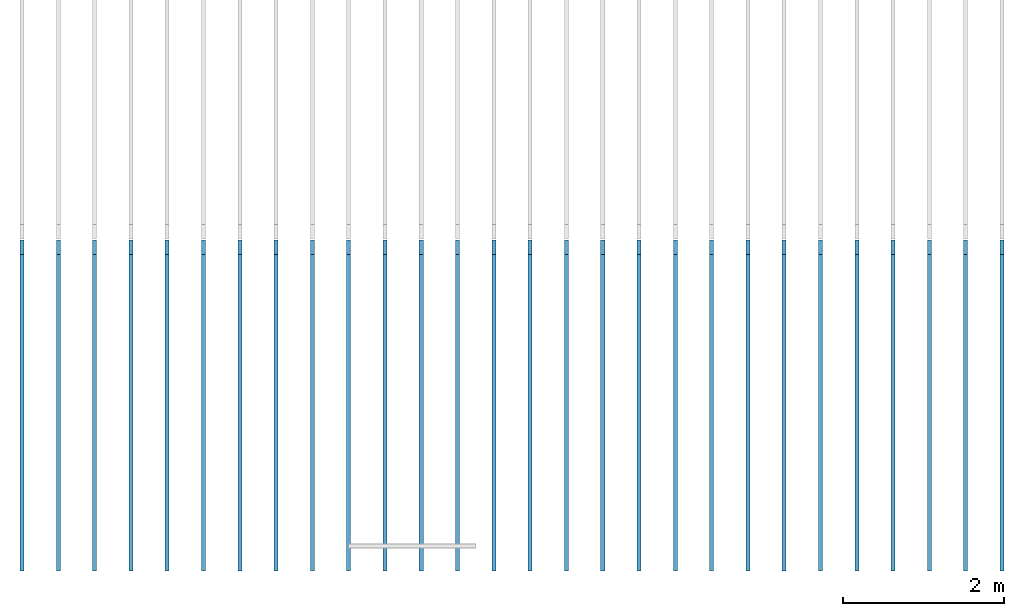
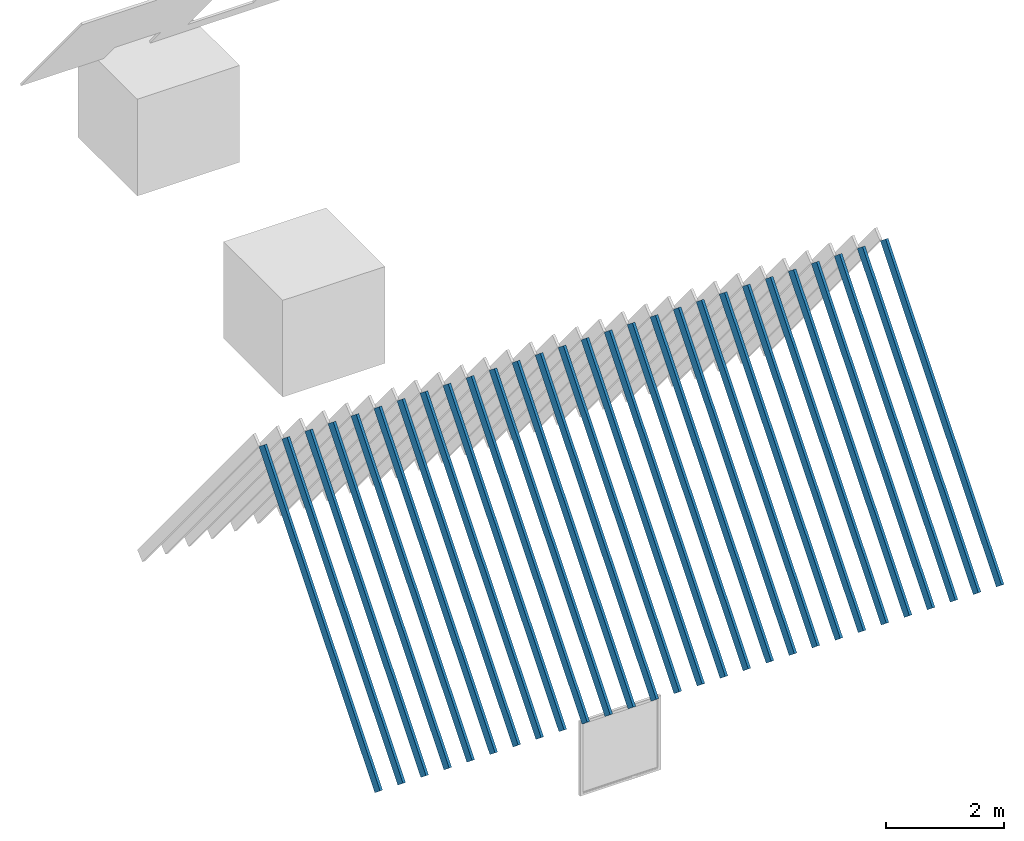
# Not in any storey, part 1 of 4: 1 member.
"""IFC4 model written with IfcOpenShell, lengths in metres."""

from ifc_helpers import new_model, entity, si_unit, converted_unit, frame, frame_2d, origin_with_axes, place, context, project, polygons, shape, element, save


model = new_model("IFC4")

# Units and contexts
model_context = context("Model", 3, precision=1e-05, world=origin_with_axes())
plan_context = context("Plan", 2, precision=1e-05, world=frame_2d((0.0, 0.0, 0.0), x_axis=(1.0, 0.0, 0.0)))
ifc_project = project(units=[si_unit("AREAUNIT", "SQUARE_METRE"), si_unit("VOLUMEUNIT", "CUBIC_METRE"), si_unit("LENGTHUNIT", "METRE"), converted_unit("PLANEANGLEUNIT", "degree", entity("IfcReal", 0.0174532925199433), si_unit("PLANEANGLEUNIT", "RADIAN"), dimensions=[0, 0, 0, 0, 0, 0, 0])], contexts=[model_context, plan_context])

# Member
member_placement = place(None, frame((-7.88622856140137, -14.2160263061523, 4.8522891998291), z_axis=(1.0, 5.00048429330491e-07, -1.79189484583731e-07), x_axis=(-1.79189484583731e-07, 0.635131001472473, 0.772404432296753)))
element("IfcMember", 1, at=member_placement, Name="Roof_Joists", PredefinedType="BRACE", shapes=[
    shape(model_context, None, "Tessellation", [polygons([(-3.09032249450684, -0.114181444048882, -0.025000000372529), (3.09032249450684, -0.114181444048882, -0.025000000372529), (-3.09032249450684, 0.114181444048882, -0.025000000372529), (3.09032249450684, 0.114181444048882, -0.025000000372529), (-3.09032249450684, 0.114181444048882, 0.025000000372529), (3.09032249450684, 0.114181444048882, 0.025000000372529), (-3.09032249450684, -0.114181444048882, 0.025000000372529), (3.09032249450684, -0.114181444048882, 0.025000000372529), (-3.09032249450684, -0.114181444048882, 0.424999982118607), (3.09032249450684, -0.114181444048882, 0.424999982118607), (-3.09032249450684, 0.114181444048882, 0.424999982118607), (3.09032249450684, 0.114181444048882, 0.424999982118607), (-3.09032249450684, 0.114181444048882, 0.474999994039536), (3.09032249450684, 0.114181444048882, 0.474999994039536), (-3.09032249450684, -0.114181444048882, 0.474999994039536), (3.09032249450684, -0.114181444048882, 0.474999994039536), (-3.09032249450684, -0.114181444048882, 0.875), (3.09032249450684, -0.114181444048882, 0.875), (-3.09032249450684, 0.114181444048882, 0.875), (3.09032249450684, 0.114181444048882, 0.875), (-3.09032249450684, 0.114181444048882, 0.924999952316284), (3.09032249450684, 0.114181444048882, 0.924999952316284), (-3.09032249450684, -0.114181444048882, 0.924999952316284), (3.09032249450684, -0.114181444048882, 0.924999952316284), (-3.09032249450684, -0.114181444048882, 1.32499992847443), (3.09032249450684, -0.114181444048882, 1.32499992847443), (-3.09032249450684, 0.114181444048882, 1.32499992847443), (3.09032249450684, 0.114181444048882, 1.32499992847443), (-3.09032249450684, 0.114181444048882, 1.37499988079071), (3.09032249450684, 0.114181444048882, 1.37499988079071), (-3.09032249450684, -0.114181444048882, 1.37499988079071), (3.09032249450684, -0.114181444048882, 1.37499988079071), (-3.09032249450684, -0.114181444048882, 1.77499997615814), (3.09032249450684, -0.114181444048882, 1.77499997615814), (-3.09032249450684, 0.114181444048882, 1.77499997615814), (3.09032249450684, 0.114181444048882, 1.77499997615814), (-3.09032249450684, 0.114181444048882, 1.82499992847443), (3.09032249450684, 0.114181444048882, 1.82499992847443), (-3.09032249450684, -0.114181444048882, 1.82499992847443), (3.09032249450684, -0.114181444048882, 1.82499992847443), (-3.09032249450684, -0.114181444048882, 2.22499990463257), (3.09032249450684, -0.114181444048882, 2.22499990463257), (-3.09032249450684, 0.114181444048882, 2.22499990463257), (3.09032249450684, 0.114181444048882, 2.22499990463257), (-3.09032249450684, 0.114181444048882, 2.27500009536743), (3.09032249450684, 0.114181444048882, 2.27500009536743), (-3.09032249450684, -0.114181444048882, 2.27500009536743), (3.09032249450684, -0.114181444048882, 2.27500009536743), (-3.09032249450684, -0.114181444048882, 2.67499995231628), (3.09032249450684, -0.114181444048882, 2.67499995231628), (-3.09032249450684, 0.114181444048882, 2.67499995231628), (3.09032249450684, 0.114181444048882, 2.67499995231628), (-3.09032249450684, 0.114181444048882, 2.72500014305115), (3.09032249450684, 0.114181444048882, 2.72500014305115), (-3.09032249450684, -0.114181444048882, 2.72500014305115), (3.09032249450684, -0.114181444048882, 2.72500014305115), (-3.09032249450684, -0.114181444048882, 3.125), (3.09032249450684, -0.114181444048882, 3.125), (-3.09032249450684, 0.114181444048882, 3.125), (3.09032249450684, 0.114181444048882, 3.125), (-3.09032249450684, 0.114181444048882, 3.17500019073486), (3.09032249450684, 0.114181444048882, 3.17500019073486), (-3.09032249450684, -0.114181444048882, 3.17500019073486), (3.09032249450684, -0.114181444048882, 3.17500019073486), (-3.09032249450684, -0.114181444048882, 3.57500004768372), (3.09032249450684, -0.114181444048882, 3.57500004768372), (-3.09032249450684, 0.114181444048882, 3.57500004768372), (3.09032249450684, 0.114181444048882, 3.57500004768372), (-3.09032249450684, 0.114181444048882, 3.62500023841858), (3.09032249450684, 0.114181444048882, 3.62500023841858), (-3.09032249450684, -0.114181444048882, 3.62500023841858), (3.09032249450684, -0.114181444048882, 3.62500023841858), (-3.09032249450684, -0.114181444048882, 4.02500009536743), (3.09032249450684, -0.114181444048882, 4.02500009536743), (-3.09032249450684, 0.114181444048882, 4.02500009536743), (3.09032249450684, 0.114181444048882, 4.02500009536743), (-3.09032249450684, 0.114181444048882, 4.07500028610229), (3.09032249450684, 0.114181444048882, 4.07500028610229), (-3.09032249450684, -0.114181444048882, 4.07500028610229), (3.09032249450684, -0.114181444048882, 4.07500028610229), (-3.09032249450684, -0.114181444048882, 4.47499990463257), (3.09032249450684, -0.114181444048882, 4.47499990463257), (-3.09032249450684, 0.114181444048882, 4.47499990463257), (3.09032249450684, 0.114181444048882, 4.47499990463257), (-3.09032249450684, 0.114181444048882, 4.52500009536743), (3.09032249450684, 0.114181444048882, 4.52500009536743), (-3.09032249450684, -0.114181444048882, 4.52500009536743), (3.09032249450684, -0.114181444048882, 4.52500009536743), (-3.09032249450684, -0.114181444048882, 4.92499971389771), (3.09032249450684, -0.114181444048882, 4.92499971389771), (-3.09032249450684, 0.114181444048882, 4.92499971389771), (3.09032249450684, 0.114181444048882, 4.92499971389771), (-3.09032249450684, 0.114181444048882, 4.97499990463257), (3.09032249450684, 0.114181444048882, 4.97499990463257), (-3.09032249450684, -0.114181444048882, 4.97499990463257), (3.09032249450684, -0.114181444048882, 4.97499990463257), (-3.09032249450684, -0.114181444048882, 5.37499952316284), (3.09032249450684, -0.114181444048882, 5.37499952316284), (-3.09032249450684, 0.114181444048882, 5.37499952316284), (3.09032249450684, 0.114181444048882, 5.37499952316284), (-3.09032249450684, 0.114181444048882, 5.42499971389771), (3.09032249450684, 0.114181444048882, 5.42499971389771), (-3.09032249450684, -0.114181444048882, 5.42499971389771), (3.09032249450684, -0.114181444048882, 5.42499971389771), (-3.09032249450684, -0.114181444048882, 5.82499933242798), (3.09032249450684, -0.114181444048882, 5.82499933242798), (-3.09032249450684, 0.114181444048882, 5.82499933242798), (3.09032249450684, 0.114181444048882, 5.82499933242798), (-3.09032249450684, 0.114181444048882, 5.87499952316284), (3.09032249450684, 0.114181444048882, 5.87499952316284), (-3.09032249450684, -0.114181444048882, 5.87499952316284), (3.09032249450684, -0.114181444048882, 5.87499952316284), (-3.09032249450684, -0.114181444048882, 6.27499914169312), (3.09032249450684, -0.114181444048882, 6.27499914169312), (-3.09032249450684, 0.114181444048882, 6.27499914169312), (3.09032249450684, 0.114181444048882, 6.27499914169312), (-3.09032249450684, 0.114181444048882, 6.32499933242798), (3.09032249450684, 0.114181444048882, 6.32499933242798), (-3.09032249450684, -0.114181444048882, 6.32499933242798), (3.09032249450684, -0.114181444048882, 6.32499933242798), (-3.09032249450684, -0.114181444048882, 6.72499895095825), (3.09032249450684, -0.114181444048882, 6.72499895095825), (-3.09032249450684, 0.114181444048882, 6.72499895095825), (3.09032249450684, 0.114181444048882, 6.72499895095825), (-3.09032249450684, 0.114181444048882, 6.77499914169312), (3.09032249450684, 0.114181444048882, 6.77499914169312), (-3.09032249450684, -0.114181444048882, 6.77499914169312), (3.09032249450684, -0.114181444048882, 6.77499914169312), (-3.09032249450684, -0.114181444048882, 7.17499876022339), (3.09032249450684, -0.114181444048882, 7.17499876022339), (-3.09032249450684, 0.114181444048882, 7.17499876022339), (3.09032249450684, 0.114181444048882, 7.17499876022339), (-3.09032249450684, 0.114181444048882, 7.22499895095825), (3.09032249450684, 0.114181444048882, 7.22499895095825), (-3.09032249450684, -0.114181444048882, 7.22499895095825), (3.09032249450684, -0.114181444048882, 7.22499895095825), (-3.09032249450684, -0.114181444048882, 7.62499856948853), (3.09032249450684, -0.114181444048882, 7.62499856948853), (-3.09032249450684, 0.114181444048882, 7.62499856948853), (3.09032249450684, 0.114181444048882, 7.62499856948853), (-3.09032249450684, 0.114181444048882, 7.67499876022339), (3.09032249450684, 0.114181444048882, 7.67499876022339), (-3.09032249450684, -0.114181444048882, 7.67499876022339), (3.09032249450684, -0.114181444048882, 7.67499876022339), (-3.09032249450684, -0.114181444048882, 8.07499885559082), (3.09032249450684, -0.114181444048882, 8.07499885559082), (-3.09032249450684, 0.114181444048882, 8.07499885559082), (3.09032249450684, 0.114181444048882, 8.07499885559082), (-3.09032249450684, 0.114181444048882, 8.12499809265137), (3.09032249450684, 0.114181444048882, 8.12499809265137), (-3.09032249450684, -0.114181444048882, 8.12499809265137), (3.09032249450684, -0.114181444048882, 8.12499809265137), (-3.09032249450684, -0.114181444048882, 8.52499866485596), (3.09032249450684, -0.114181444048882, 8.52499866485596), (-3.09032249450684, 0.114181444048882, 8.52499866485596), (3.09032249450684, 0.114181444048882, 8.52499866485596), (-3.09032249450684, 0.114181444048882, 8.5749979019165), (3.09032249450684, 0.114181444048882, 8.5749979019165), (-3.09032249450684, -0.114181444048882, 8.5749979019165), (3.09032249450684, -0.114181444048882, 8.5749979019165), (-3.09032249450684, -0.114181444048882, 8.97499847412109), (3.09032249450684, -0.114181444048882, 8.97499847412109), (-3.09032249450684, 0.114181444048882, 8.97499847412109), (3.09032249450684, 0.114181444048882, 8.97499847412109), (-3.09032249450684, 0.114181444048882, 9.02499771118164), (3.09032249450684, 0.114181444048882, 9.02499771118164), (-3.09032249450684, -0.114181444048882, 9.02499771118164), (3.09032249450684, -0.114181444048882, 9.02499771118164), (-3.09032249450684, -0.114181444048882, 9.42499828338623), (3.09032249450684, -0.114181444048882, 9.42499828338623), (-3.09032249450684, 0.114181444048882, 9.42499828338623), (3.09032249450684, 0.114181444048882, 9.42499828338623), (-3.09032249450684, 0.114181444048882, 9.47499752044678), (3.09032249450684, 0.114181444048882, 9.47499752044678), (-3.09032249450684, -0.114181444048882, 9.47499752044678), (3.09032249450684, -0.114181444048882, 9.47499752044678), (-3.09032249450684, -0.114181444048882, 9.87499809265137), (3.09032249450684, -0.114181444048882, 9.87499809265137), (-3.09032249450684, 0.114181444048882, 9.87499809265137), (3.09032249450684, 0.114181444048882, 9.87499809265137), (-3.09032249450684, 0.114181444048882, 9.92499732971191), (3.09032249450684, 0.114181444048882, 9.92499732971191), (-3.09032249450684, -0.114181444048882, 9.92499732971191), (3.09032249450684, -0.114181444048882, 9.92499732971191), (-3.09032249450684, -0.114181444048882, 10.3249979019165), (3.09032249450684, -0.114181444048882, 10.3249979019165), (-3.09032249450684, 0.114181444048882, 10.3249979019165), (3.09032249450684, 0.114181444048882, 10.3249979019165), (-3.09032249450684, 0.114181444048882, 10.3749971389771), (3.09032249450684, 0.114181444048882, 10.3749971389771), (-3.09032249450684, -0.114181444048882, 10.3749971389771), (3.09032249450684, -0.114181444048882, 10.3749971389771), (-3.09032249450684, -0.114181444048882, 10.7749977111816), (3.09032249450684, -0.114181444048882, 10.7749977111816), (-3.09032249450684, 0.114181444048882, 10.7749977111816), (3.09032249450684, 0.114181444048882, 10.7749977111816), (-3.09032249450684, 0.114181444048882, 10.8249969482422), (3.09032249450684, 0.114181444048882, 10.8249969482422), (-3.09032249450684, -0.114181444048882, 10.8249969482422), (3.09032249450684, -0.114181444048882, 10.8249969482422), (-3.09032249450684, -0.114181444048882, 11.2249975204468), (3.09032249450684, -0.114181444048882, 11.2249975204468), (-3.09032249450684, 0.114181444048882, 11.2249975204468), (3.09032249450684, 0.114181444048882, 11.2249975204468), (-3.09032249450684, 0.114181444048882, 11.2749967575073), (3.09032249450684, 0.114181444048882, 11.2749967575073), (-3.09032249450684, -0.114181444048882, 11.2749967575073), (3.09032249450684, -0.114181444048882, 11.2749967575073), (-3.09032249450684, -0.114181444048882, 11.6749973297119), (3.09032249450684, -0.114181444048882, 11.6749973297119), (-3.09032249450684, 0.114181444048882, 11.6749973297119), (3.09032249450684, 0.114181444048882, 11.6749973297119), (-3.09032249450684, 0.114181444048882, 11.7249965667725), (3.09032249450684, 0.114181444048882, 11.7249965667725), (-3.09032249450684, -0.114181444048882, 11.7249965667725), (3.09032249450684, -0.114181444048882, 11.7249965667725), (-3.09032249450684, -0.114181444048882, 12.1249971389771), (3.09032249450684, -0.114181444048882, 12.1249971389771), (-3.09032249450684, 0.114181444048882, 12.1249971389771), (3.09032249450684, 0.114181444048882, 12.1249971389771), (-3.09032249450684, 0.114181444048882, 12.1749963760376), (3.09032249450684, 0.114181444048882, 12.1749963760376), (-3.09032249450684, -0.114181444048882, 12.1749963760376), (3.09032249450684, -0.114181444048882, 12.1749963760376)], [[[6, 4, 3, 5]], [[8, 6, 5, 7]], [[2, 8, 7, 1]], [[1, 7, 5, 3]], [[8, 2, 4, 6]], [[4, 2, 1, 3]], [[14, 12, 11, 13]], [[16, 14, 13, 15]], [[10, 16, 15, 9]], [[9, 15, 13, 11]], [[16, 10, 12, 14]], [[12, 10, 9, 11]], [[22, 20, 19, 21]], [[24, 22, 21, 23]], [[18, 24, 23, 17]], [[17, 23, 21, 19]], [[24, 18, 20, 22]], [[20, 18, 17, 19]], [[30, 28, 27, 29]], [[32, 30, 29, 31]], [[26, 32, 31, 25]], [[25, 31, 29, 27]], [[32, 26, 28, 30]], [[28, 26, 25, 27]], [[38, 36, 35, 37]], [[40, 38, 37, 39]], [[34, 40, 39, 33]], [[33, 39, 37, 35]], [[40, 34, 36, 38]], [[36, 34, 33, 35]], [[46, 44, 43, 45]], [[48, 46, 45, 47]], [[42, 48, 47, 41]], [[41, 47, 45, 43]], [[48, 42, 44, 46]], [[44, 42, 41, 43]], [[54, 52, 51, 53]], [[56, 54, 53, 55]], [[50, 56, 55, 49]], [[49, 55, 53, 51]], [[56, 50, 52, 54]], [[52, 50, 49, 51]], [[62, 60, 59, 61]], [[64, 62, 61, 63]], [[58, 64, 63, 57]], [[57, 63, 61, 59]], [[64, 58, 60, 62]], [[60, 58, 57, 59]], [[70, 68, 67, 69]], [[72, 70, 69, 71]], [[66, 72, 71, 65]], [[65, 71, 69, 67]], [[72, 66, 68, 70]], [[68, 66, 65, 67]], [[78, 76, 75, 77]], [[80, 78, 77, 79]], [[74, 80, 79, 73]], [[73, 79, 77, 75]], [[80, 74, 76, 78]], [[76, 74, 73, 75]], [[86, 84, 83, 85]], [[88, 86, 85, 87]], [[82, 88, 87, 81]], [[81, 87, 85, 83]], [[88, 82, 84, 86]], [[84, 82, 81, 83]], [[94, 92, 91, 93]], [[96, 94, 93, 95]], [[90, 96, 95, 89]], [[89, 95, 93, 91]], [[96, 90, 92, 94]], [[92, 90, 89, 91]], [[102, 100, 99, 101]], [[104, 102, 101, 103]], [[98, 104, 103, 97]], [[97, 103, 101, 99]], [[104, 98, 100, 102]], [[100, 98, 97, 99]], [[110, 108, 107, 109]], [[112, 110, 109, 111]], [[106, 112, 111, 105]], [[105, 111, 109, 107]], [[112, 106, 108, 110]], [[108, 106, 105, 107]], [[118, 116, 115, 117]], [[120, 118, 117, 119]], [[114, 120, 119, 113]], [[113, 119, 117, 115]], [[120, 114, 116, 118]], [[116, 114, 113, 115]], [[126, 124, 123, 125]], [[128, 126, 125, 127]], [[122, 128, 127, 121]], [[121, 127, 125, 123]], [[128, 122, 124, 126]], [[124, 122, 121, 123]], [[134, 132, 131, 133]], [[136, 134, 133, 135]], [[130, 136, 135, 129]], [[129, 135, 133, 131]], [[136, 130, 132, 134]], [[132, 130, 129, 131]], [[142, 140, 139, 141]], [[144, 142, 141, 143]], [[138, 144, 143, 137]], [[137, 143, 141, 139]], [[144, 138, 140, 142]], [[140, 138, 137, 139]], [[150, 148, 147, 149]], [[152, 150, 149, 151]], [[146, 152, 151, 145]], [[145, 151, 149, 147]], [[152, 146, 148, 150]], [[148, 146, 145, 147]], [[158, 156, 155, 157]], [[160, 158, 157, 159]], [[154, 160, 159, 153]], [[153, 159, 157, 155]], [[160, 154, 156, 158]], [[156, 154, 153, 155]], [[166, 164, 163, 165]], [[168, 166, 165, 167]], [[162, 168, 167, 161]], [[161, 167, 165, 163]], [[168, 162, 164, 166]], [[164, 162, 161, 163]], [[174, 172, 171, 173]], [[176, 174, 173, 175]], [[170, 176, 175, 169]], [[169, 175, 173, 171]], [[176, 170, 172, 174]], [[172, 170, 169, 171]], [[182, 180, 179, 181]], [[184, 182, 181, 183]], [[178, 184, 183, 177]], [[177, 183, 181, 179]], [[184, 178, 180, 182]], [[180, 178, 177, 179]], [[190, 188, 187, 189]], [[192, 190, 189, 191]], [[186, 192, 191, 185]], [[185, 191, 189, 187]], [[192, 186, 188, 190]], [[188, 186, 185, 187]], [[198, 196, 195, 197]], [[200, 198, 197, 199]], [[194, 200, 199, 193]], [[193, 199, 197, 195]], [[200, 194, 196, 198]], [[196, 194, 193, 195]], [[206, 204, 203, 205]], [[208, 206, 205, 207]], [[202, 208, 207, 201]], [[201, 207, 205, 203]], [[208, 202, 204, 206]], [[204, 202, 201, 203]], [[214, 212, 211, 213]], [[216, 214, 213, 215]], [[210, 216, 215, 209]], [[209, 215, 213, 211]], [[216, 210, 212, 214]], [[212, 210, 209, 211]], [[222, 220, 219, 221]], [[222, 223, 224]], [[218, 224, 223, 217]], [[217, 223, 221, 219]], [[224, 218, 220, 222]], [[218, 219, 220]], [[222, 221, 223]], [[218, 217, 219]]])]),
])

save(model, "model.ifc")
